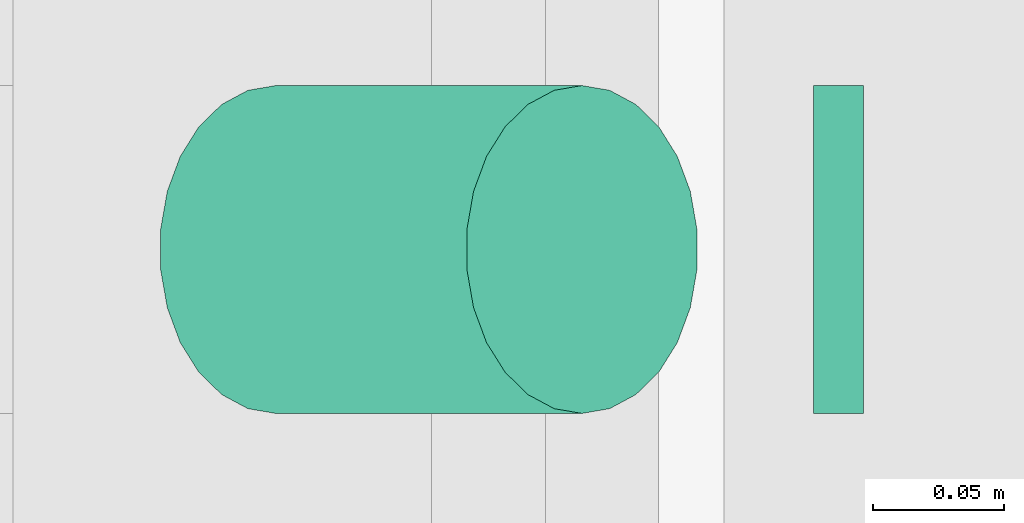
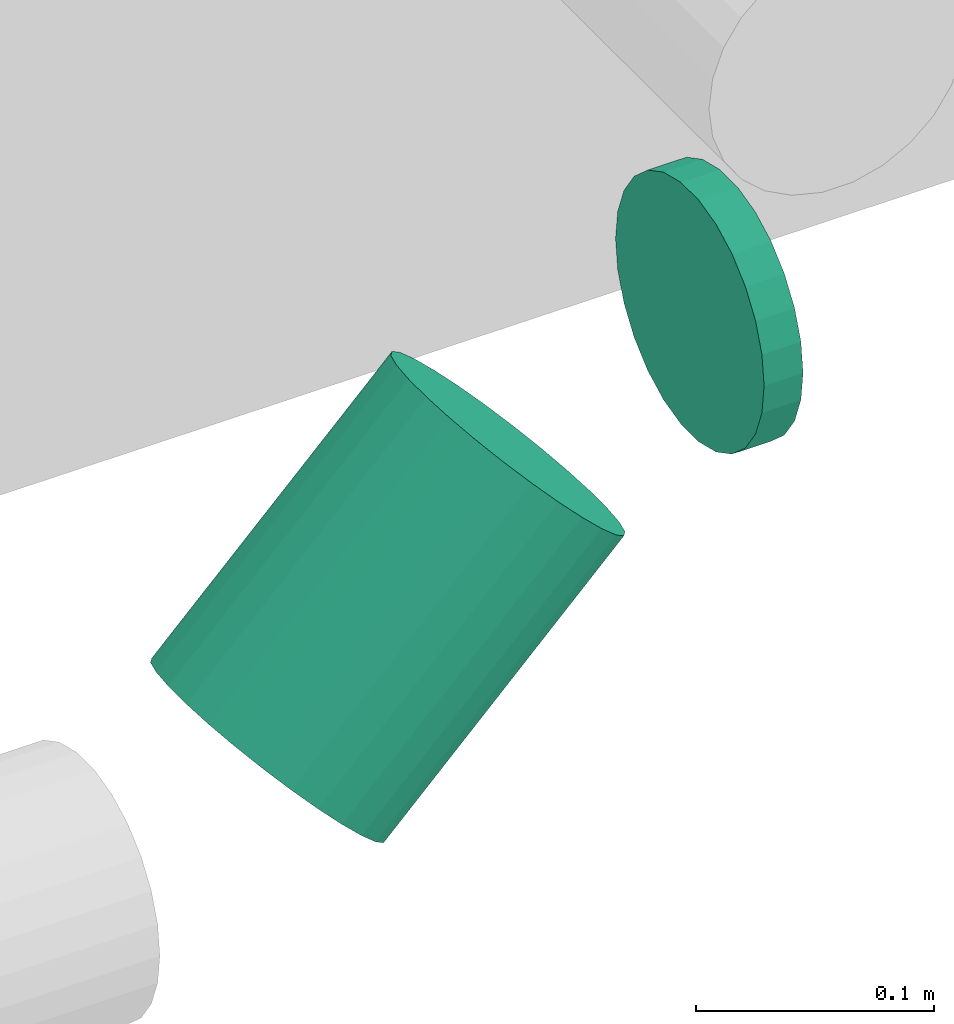
# One storey, part 201 of 337: 2 flow segments.
"""IFC2X3 building model written with IfcOpenShell, lengths in millimetres."""

from ifc_helpers import new_model, entity, si_unit, converted_unit, derived_unit, direction, frame, origin, origin_2d_with_axis, place, context, subcontext, project, spatial, circle, extrude, type_object, element, save


model = new_model("IFC2X3")

# Units and contexts
model_context = context("Model", 3, precision=0.01, world=origin(), true_north=direction((6.12303176911189e-17, 1.0)))
body_context = subcontext(model_context, "Body", "Model", "MODEL_VIEW")
ifc_project = project(units=[si_unit("LENGTHUNIT", "METRE", prefix="MILLI"), si_unit("AREAUNIT", "SQUARE_METRE"), si_unit("VOLUMEUNIT", "CUBIC_METRE"), converted_unit("PLANEANGLEUNIT", "DEGREE", entity("IfcRatioMeasure", 0.0174532925199433), si_unit("PLANEANGLEUNIT", "RADIAN"), dimensions=[0, 0, 0, 0, 0, 0, 0]), si_unit("MASSUNIT", "GRAM", prefix="KILO"), derived_unit("MASSDENSITYUNIT", [(si_unit("MASSUNIT", "GRAM", prefix="KILO"), 1), (si_unit("LENGTHUNIT", "METRE"), -3)]), derived_unit("MOMENTOFINERTIAUNIT", [(si_unit("LENGTHUNIT", "METRE"), 4)]), si_unit("TIMEUNIT", "SECOND"), si_unit("FREQUENCYUNIT", "HERTZ"), si_unit("THERMODYNAMICTEMPERATUREUNIT", "DEGREE_CELSIUS"), derived_unit("THERMALTRANSMITTANCEUNIT", [(si_unit("MASSUNIT", "GRAM", prefix="KILO"), 1), (si_unit("THERMODYNAMICTEMPERATUREUNIT", "KELVIN"), -1), (si_unit("TIMEUNIT", "SECOND"), -3)]), derived_unit("VOLUMETRICFLOWRATEUNIT", [(si_unit("LENGTHUNIT", "METRE"), 3), (si_unit("TIMEUNIT", "SECOND"), -1)]), derived_unit("MASSFLOWRATEUNIT", [(si_unit("MASSUNIT", "GRAM", prefix="KILO"), 1), (si_unit("TIMEUNIT", "SECOND"), -1)]), derived_unit("ROTATIONALFREQUENCYUNIT", [(si_unit("TIMEUNIT", "SECOND"), -1)]), si_unit("ELECTRICCURRENTUNIT", "AMPERE"), si_unit("ELECTRICVOLTAGEUNIT", "VOLT"), si_unit("POWERUNIT", "WATT"), si_unit("FORCEUNIT", "NEWTON", prefix="KILO"), si_unit("ILLUMINANCEUNIT", "LUX"), si_unit("LUMINOUSFLUXUNIT", "LUMEN"), si_unit("LUMINOUSINTENSITYUNIT", "CANDELA"), derived_unit("USERDEFINED", [(si_unit("MASSUNIT", "GRAM", prefix="KILO"), -1), (si_unit("LENGTHUNIT", "METRE"), -2), (si_unit("TIMEUNIT", "SECOND"), 3), (si_unit("LUMINOUSFLUXUNIT", "LUMEN"), 1)]), derived_unit("LINEARVELOCITYUNIT", [(si_unit("LENGTHUNIT", "METRE"), 1), (si_unit("TIMEUNIT", "SECOND"), -1)]), si_unit("PRESSUREUNIT", "PASCAL"), derived_unit("USERDEFINED", [(si_unit("LENGTHUNIT", "METRE"), -2), (si_unit("MASSUNIT", "GRAM", prefix="KILO"), 1), (si_unit("TIMEUNIT", "SECOND"), -2)]), derived_unit("LINEARFORCEUNIT", [(si_unit("MASSUNIT", "GRAM", prefix="KILO"), 1), (si_unit("LENGTHUNIT", "METRE"), 1), (si_unit("TIMEUNIT", "SECOND"), -2), (si_unit("LENGTHUNIT", "METRE"), -1)]), derived_unit("PLANARFORCEUNIT", [(si_unit("MASSUNIT", "GRAM", prefix="KILO"), 1), (si_unit("LENGTHUNIT", "METRE"), 1), (si_unit("TIMEUNIT", "SECOND"), -2), (si_unit("LENGTHUNIT", "METRE"), -2)])], contexts=[model_context])

# Site, building, storey
site_placement = place(None, origin())
site = spatial("IfcSite", under=ifc_project, at=site_placement, CompositionType="ELEMENT")
building_placement = place(site_placement, origin())
building = spatial("IfcBuilding", under=site, at=building_placement, CompositionType="ELEMENT")
storey_placement = place(building_placement, origin())
storey = spatial("IfcBuildingStorey", under=building, at=storey_placement, CompositionType="ELEMENT", Elevation=0.0)

# Flow segments
duct_segment_type = type_object("IfcDuctSegmentType", PredefinedType="NOTDEFINED")
flow_segment_1_placement = place(storey_placement, frame((50982.42, 14338.22, -574.1)))
element("IfcFlowSegment", 1, at=flow_segment_1_placement, inside=storey, type_object=duct_segment_type, context=body_context, shape_type="SweptSolid", body=[
    extrude(circle(Radius=62.5, at=origin_2d_with_axis()), frame((0.0, 64.1, 64.1), z_axis=(1.0, 0.0, 0.0), x_axis=(0.0, 1.0, 0.0)), (0.0, 0.0, 1.0), 18.9433087033923),
])
flow_segment_2_placement = place(storey_placement, frame((50731.47, 14338.22, -709.18)))
element("IfcFlowSegment", 2, at=flow_segment_2_placement, inside=storey, type_object=duct_segment_type, context=body_context, shape_type="SweptSolid", body=[
    extrude(circle(Radius=62.5, at=origin_2d_with_axis()), frame((45.79, 64.1, 45.79), z_axis=(0.707106781186513, 0.0, 0.707106781186582), x_axis=(0.0, 1.0, 0.0)), (0.0, 0.0, 1.0), 165.147186257652),
])

save(model, "model.ifc")
